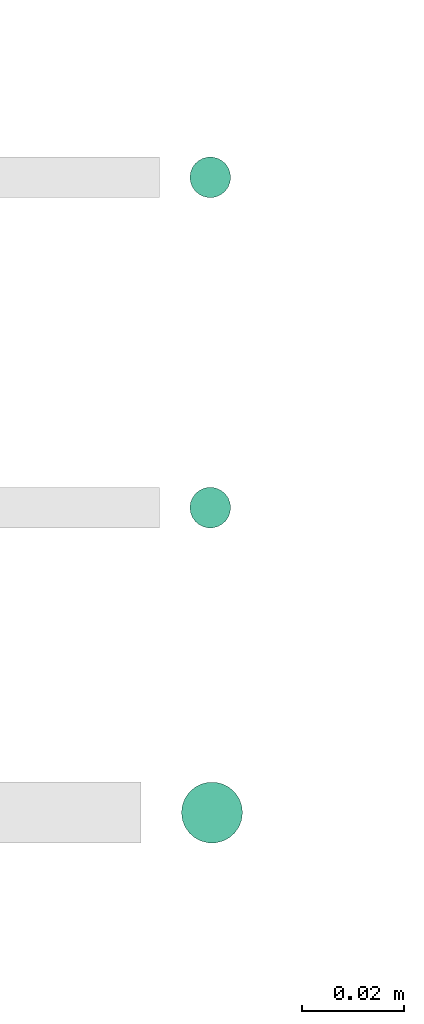
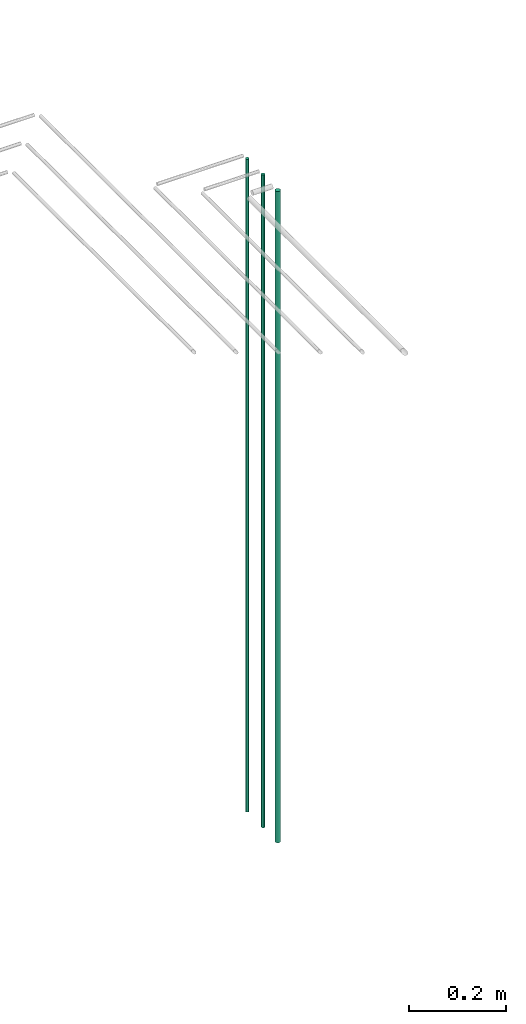
# One storey, part 105 of 331: 3 flow segments.
"""IFC2X3 building model written with IfcOpenShell, lengths in millimetres."""

from ifc_helpers import new_model, entity, si_unit, converted_unit, derived_unit, direction, frame, origin, origin_2d_with_axis, place, context, subcontext, project, spatial, circle, extrude, type_object, element, save


model = new_model("IFC2X3")

# Units and contexts
model_context = context("Model", 3, precision=0.01, world=origin(), true_north=direction((6.12303176911189e-17, 1.0)))
body_context = subcontext(model_context, "Body", "Model", "MODEL_VIEW")
ifc_project = project(units=[si_unit("LENGTHUNIT", "METRE", prefix="MILLI"), si_unit("AREAUNIT", "SQUARE_METRE"), si_unit("VOLUMEUNIT", "CUBIC_METRE"), converted_unit("PLANEANGLEUNIT", "DEGREE", entity("IfcRatioMeasure", 0.0174532925199433), si_unit("PLANEANGLEUNIT", "RADIAN"), dimensions=[0, 0, 0, 0, 0, 0, 0]), si_unit("MASSUNIT", "GRAM", prefix="KILO"), derived_unit("MASSDENSITYUNIT", [(si_unit("MASSUNIT", "GRAM", prefix="KILO"), 1), (si_unit("LENGTHUNIT", "METRE"), -3)]), derived_unit("MOMENTOFINERTIAUNIT", [(si_unit("LENGTHUNIT", "METRE"), 4)]), si_unit("TIMEUNIT", "SECOND"), si_unit("FREQUENCYUNIT", "HERTZ"), si_unit("THERMODYNAMICTEMPERATUREUNIT", "DEGREE_CELSIUS"), derived_unit("THERMALTRANSMITTANCEUNIT", [(si_unit("MASSUNIT", "GRAM", prefix="KILO"), 1), (si_unit("THERMODYNAMICTEMPERATUREUNIT", "KELVIN"), -1), (si_unit("TIMEUNIT", "SECOND"), -3)]), derived_unit("VOLUMETRICFLOWRATEUNIT", [(si_unit("LENGTHUNIT", "METRE"), 3), (si_unit("TIMEUNIT", "SECOND"), -1)]), derived_unit("MASSFLOWRATEUNIT", [(si_unit("MASSUNIT", "GRAM", prefix="KILO"), 1), (si_unit("TIMEUNIT", "SECOND"), -1)]), derived_unit("ROTATIONALFREQUENCYUNIT", [(si_unit("TIMEUNIT", "SECOND"), -1)]), si_unit("ELECTRICCURRENTUNIT", "AMPERE"), si_unit("ELECTRICVOLTAGEUNIT", "VOLT"), si_unit("POWERUNIT", "WATT"), si_unit("FORCEUNIT", "NEWTON", prefix="KILO"), si_unit("ILLUMINANCEUNIT", "LUX"), si_unit("LUMINOUSFLUXUNIT", "LUMEN"), si_unit("LUMINOUSINTENSITYUNIT", "CANDELA"), derived_unit("USERDEFINED", [(si_unit("MASSUNIT", "GRAM", prefix="KILO"), -1), (si_unit("LENGTHUNIT", "METRE"), -2), (si_unit("TIMEUNIT", "SECOND"), 3), (si_unit("LUMINOUSFLUXUNIT", "LUMEN"), 1)]), derived_unit("LINEARVELOCITYUNIT", [(si_unit("LENGTHUNIT", "METRE"), 1), (si_unit("TIMEUNIT", "SECOND"), -1)]), si_unit("PRESSUREUNIT", "PASCAL"), derived_unit("USERDEFINED", [(si_unit("LENGTHUNIT", "METRE"), -2), (si_unit("MASSUNIT", "GRAM", prefix="KILO"), 1), (si_unit("TIMEUNIT", "SECOND"), -2)]), derived_unit("LINEARFORCEUNIT", [(si_unit("MASSUNIT", "GRAM", prefix="KILO"), 1), (si_unit("LENGTHUNIT", "METRE"), 1), (si_unit("TIMEUNIT", "SECOND"), -2), (si_unit("LENGTHUNIT", "METRE"), -1)]), derived_unit("PLANARFORCEUNIT", [(si_unit("MASSUNIT", "GRAM", prefix="KILO"), 1), (si_unit("LENGTHUNIT", "METRE"), 1), (si_unit("TIMEUNIT", "SECOND"), -2), (si_unit("LENGTHUNIT", "METRE"), -2)])], contexts=[model_context])

# Site, building, storey
site_placement = place(None, frame((0.0, -0.00077364408347762, 0.0)))
site = spatial("IfcSite", under=ifc_project, at=site_placement, CompositionType="ELEMENT")
building_placement = place(site_placement, origin())
building = spatial("IfcBuilding", under=site, at=building_placement, CompositionType="ELEMENT")
storey_placement = place(building_placement, origin())
storey = spatial("IfcBuildingStorey", under=building, at=storey_placement, CompositionType="ELEMENT", Elevation=0.0)

# Flow segments
pipe_segment_type = type_object("IfcPipeSegmentType", PredefinedType="NOTDEFINED")
flow_segment_placement = place(storey_placement, frame((41587.4054235649, 19495.6773259281, 5700.0)))
element("IfcFlowSegment", 1, at=flow_segment_placement, inside=storey, type_object=pipe_segment_type, context=body_context, shape_type="SweptSolid", body=[
    extrude(circle(Radius=6.0, at=origin_2d_with_axis()), frame((7.59527223591454, 7.59527223591454, 0.0)), (0.0, 0.0, 1.0), 1636.0),
])
for number, where in (
    (2, (41589.0665845049, 19557.6765034793, 5700.0)),
    (3, (41589.0665845049, 19622.6765034793, 5700.0)),
):
    element("IfcFlowSegment", number, at=place(storey_placement, frame(where)), inside=storey, type_object=pipe_segment_type, context=body_context, shape_type="SweptSolid", body=[
        extrude(circle(Radius=4.0, at=origin_2d_with_axis()), frame((5.59527223591499, 5.59527223591499, 0.0)), (0.0, 0.0, 1.0), 1640.0),
    ])

save(model, "model.ifc")
